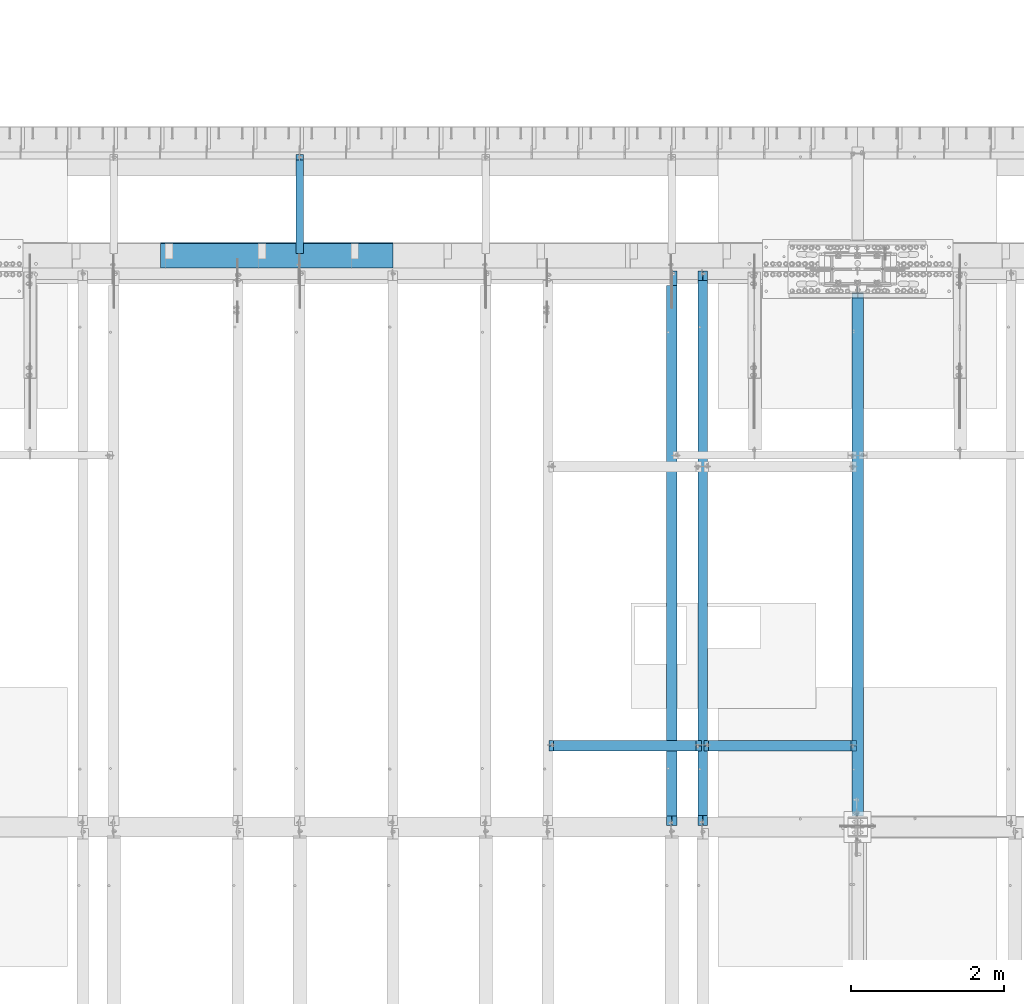
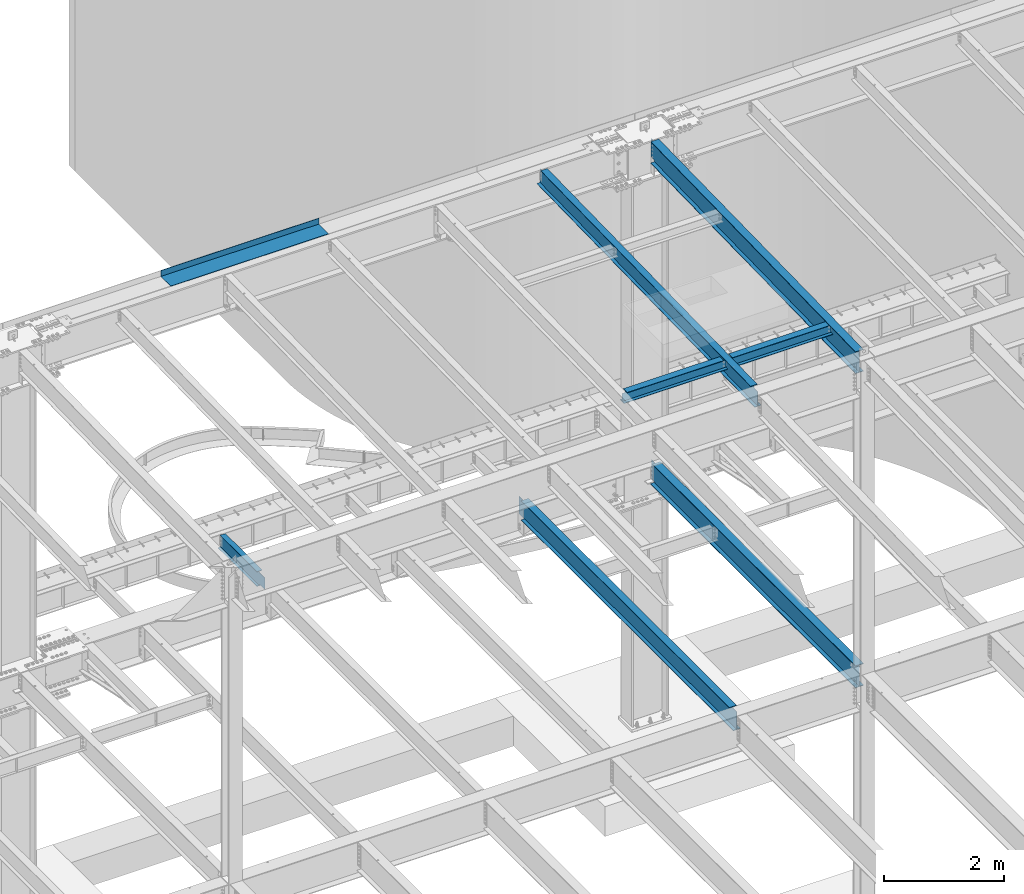
# One storey, part 1134 of 1763: 8 beams, 8 elements without a shape of their own.
"""IFC2X3 building model written with IfcOpenShell, lengths in millimetres."""

from ifc_helpers import new_model, si_unit, frame, origin_with_axes, place, context, subcontext, project, spatial, faceted_brep, material, type_object, element, aggregate, save


model = new_model("IFC2X3")

# Units and contexts
model_context = context("Model", 3, precision=1e-05, world=origin_with_axes())
body_context = subcontext(model_context, "Body", "Model", "MODEL_VIEW")
ifc_project = project(units=[si_unit("LENGTHUNIT", "METRE", prefix="MILLI"), si_unit("AREAUNIT", "SQUARE_METRE"), si_unit("VOLUMEUNIT", "CUBIC_METRE"), si_unit("MASSUNIT", "GRAM", prefix="KILO"), si_unit("TIMEUNIT", "SECOND"), si_unit("PLANEANGLEUNIT", "RADIAN"), si_unit("SOLIDANGLEUNIT", "STERADIAN"), si_unit("THERMODYNAMICTEMPERATUREUNIT", "DEGREE_CELSIUS"), si_unit("LUMINOUSINTENSITYUNIT", "LUMEN")], contexts=[model_context])

# Site, building, storey
site_placement = place(None, origin_with_axes())
site = spatial("IfcSite", under=ifc_project, at=site_placement, CompositionType="ELEMENT")
building_placement = place(site_placement, origin_with_axes())
building = spatial("IfcBuilding", under=site, at=building_placement, Name="Undefined", CompositionType="ELEMENT")
storey_placement = place(building_placement, origin_with_axes())
storey = spatial("IfcBuildingStorey", under=building, at=storey_placement, Name="Undefined", CompositionType="ELEMENT", Elevation=0.0)

# Assembly, beam
assembly_1_placement = place(storey_placement, origin_with_axes())
assembly_1 = element("IfcElementAssembly", 1, at=assembly_1_placement, inside=storey, Name="BEAM", AssemblyPlace="NOTDEFINED", PredefinedType="RIGID_FRAME")
ifc_material_1 = material(Name="STEEL/A992")
beam_type_1 = type_object("IfcBeamType", Name="W8X18", PredefinedType="NOTDEFINED")
beam_1_placement = place(assembly_1_placement, frame((-53466.5223188412, 45872.003125, 11515.9111170495), z_axis=(0.0, 0.0, 1.0), x_axis=(1.0, 0.0, 0.0)))
beam_1 = element("IfcBeam", 2, at=beam_1_placement, type_object=beam_type_1, material=ifc_material_1, Name="BEAM", ObjectType="W8X18", context=body_context, shape_type="Brep", body=[
    faceted_brep([(1947.72688668019, -3.17500000383734, 68.5472454981009), (1947.7268866802, 3.1749999961612, 68.5472454981009), (1946.86590192084, 3.17499999616848, 69.8358002505338), (1946.86590177228, -3.17500000383006, 69.8358004728379), (1951.84706314834, -3.17500000384462, 65.7942315976234), (1951.84706314836, 3.17499999615393, 65.7942315976234), (1956.70714266639, -3.17500000385189, 64.8275016750358), (1956.7071426664, 3.17499999614665, 64.8275016750358), (2015.44464294919, -3.17500000397558, 64.8275016750358), (2015.44464276504, 3.17499999602296, 64.8275016750358), (1946.13938981476, -3.17500000383006, 70.3212402430472), (1946.13938963061, 3.17499999616848, 70.3212402430472), (1943.38637573014, 3.17499999617576, 74.4414167112009), (1943.38637591428, -3.17500000383006, 74.4414167112009), (1942.41964580755, 3.17499999617576, 79.3014962292473), (1942.41964599169, -3.17500000382279, 79.3014962292473), (76.1999968561649, 3.17499999984284, 95.25), (76.1999950146637, 66.6749999998428, 95.25), (1942.41964396604, 66.6749999961758, 95.25), (1942.41964580755, 3.17499999617576, 95.25), (76.1999988818134, -66.6750000001557, 103.1875), (76.1999988818134, -66.6750000001557, 95.25), (1942.41964783319, -66.6750000038228, 95.25), (1942.41964783319, -66.6750000038228, 103.1875), (76.1999950146637, 66.6749999998428, 103.1875), (1942.41964396604, 66.6749999961758, 103.1875), (1942.41964599169, -3.17500000382279, 95.25), (76.1999970403122, -3.17500000015571, 95.25), (76.1999968561649, 3.17499999984284, 79.3014961863064), (76.1999970403122, -3.17500000015571, 79.3014961863064), (75.2332669335738, 3.17499999985012, 74.44141666826), (75.233267117721, -3.17500000014843, 74.44141666826), (72.4802530330999, 3.17499999985012, 70.3212402001063), (72.4802532172471, -3.17500000014843, 70.3212402001063), (71.7537410457226, 3.17499999985739, 69.83580040995), (71.7537408971693, -3.17500000014115, 69.8358001876459), (70.8927561769378, 3.17499999985739, 68.5472454937626), (70.8927561769233, -3.17500000014115, 68.5472454937626), (66.7725797087842, 3.17499999986467, 65.7942315932851), (66.7725797087696, -3.17500000013388, 65.7942315932851), (61.912500190745, 3.17499999987194, 64.8275016706975), (61.9125001907232, -3.1750000001266, 64.8275016706975), (15.8749999079228, 3.17499999996653, 64.8275016706975), (15.87500009207, -3.17500000003201, 64.8275016706975), (15.8749999079228, 3.17499999996653, -95.25), (15.8749980664215, 66.6749999999665, -95.25), (15.8749980664215, 66.6749999999665, -103.1875), (15.8750019335712, -66.675000000032, -103.1875), (15.8750019335712, -66.675000000032, -95.25), (15.87500009207, -3.17500000003201, -95.25), (2015.44464276504, 3.17499999602296, -95.25), (2015.44464092355, 66.674999996023, -95.25), (2015.44464092355, 66.674999996023, -103.1875), (2015.4446447907, -66.6750000039756, -103.1875), (2015.4446447907, -66.6750000039756, -95.25), (2015.44464294919, -3.17500000397558, -95.25)], [[[0, 1, 2, 3]], [[4, 5, 1, 0]], [[6, 7, 5, 4]], [[8, 9, 7, 6]], [[10, 11, 12, 13]], [[13, 12, 14, 15]], [[16, 17, 18, 19]], [[20, 21, 22, 23]], [[24, 20, 23, 25]], [[17, 24, 25, 18]], [[23, 22, 26, 15, 14, 19, 18, 25]], [[21, 27, 26, 22]], [[20, 24, 17, 16, 28, 29, 27, 21]], [[29, 28, 30, 31]], [[31, 30, 32, 33]], [[33, 32, 34, 35]], [[35, 34, 36, 37]], [[37, 36, 38, 39]], [[39, 38, 40, 41]], [[41, 40, 42, 43]], [[44, 45, 46, 47, 48, 49, 43, 42]], [[45, 44, 50, 51]], [[46, 45, 51, 52]], [[47, 46, 52, 53]], [[48, 47, 53, 54]], [[49, 48, 54, 55]], [[4, 0, 3, 10, 13, 15, 26, 27, 29, 31, 33, 35, 37, 39, 41, 43, 49, 55, 8, 6]], [[11, 10, 3, 2]], [[50, 44, 42, 40, 38, 36, 34, 32, 30, 28, 16, 19, 14, 12, 11, 2, 1, 5, 7, 9]], [[55, 54, 53, 52, 51, 50, 9, 8]]]),
])
aggregate(assembly_1, [beam_1])

assembly_2_placement = place(storey_placement, origin_with_axes())
assembly_2 = element("IfcElementAssembly", 3, at=assembly_2_placement, inside=storey, Name="BEAM", AssemblyPlace="NOTDEFINED", PredefinedType="RIGID_FRAME")
beam_2_placement = place(assembly_2_placement, frame((-51434.5223188412, 45872.003125, 11515.9111170495), z_axis=(0.0, 0.0, 1.0), x_axis=(1.0, 0.0, 0.0)))
beam_2 = element("IfcBeam", 4, at=beam_2_placement, type_object=beam_type_1, material=ifc_material_1, Name="BEAM", ObjectType="W8X18", context=body_context, shape_type="Brep", body=[
    faceted_brep([(1947.72688668019, -3.17500000383734, 68.5472454981009), (1947.7268866802, 3.1749999961612, 68.5472454981009), (1946.86590192084, 3.17499999616848, 69.8358002505338), (1946.86590177228, -3.17500000383006, 69.8358004728379), (1951.84706314834, -3.17500000384462, 65.7942315976234), (1951.84706314836, 3.17499999615393, 65.7942315976234), (1956.70714266639, -3.17500000385189, 64.8275016750358), (1956.7071426664, 3.17499999614665, 64.8275016750358), (2015.44464294919, -3.17500000397558, 64.8275016750358), (2015.44464276504, 3.17499999602296, 64.8275016750358), (1946.13938981476, -3.17500000383006, 70.3212402430472), (1946.13938963061, 3.17499999616848, 70.3212402430472), (1943.38637573014, 3.17499999617576, 74.4414167112009), (1943.38637591428, -3.17500000383006, 74.4414167112009), (1942.41964580755, 3.17499999617576, 79.3014962292473), (1942.41964599169, -3.17500000382279, 79.3014962292473), (76.1999968561649, 3.17499999984284, 95.25), (76.1999950146637, 66.6749999998428, 95.25), (1942.41964396604, 66.6749999961758, 95.25), (1942.41964580755, 3.17499999617576, 95.25), (76.1999988818134, -66.6750000001557, 103.1875), (76.1999988818134, -66.6750000001557, 95.25), (1942.41964783319, -66.6750000038228, 95.25), (1942.41964783319, -66.6750000038228, 103.1875), (76.1999950146637, 66.6749999998428, 103.1875), (1942.41964396604, 66.6749999961758, 103.1875), (1942.41964599169, -3.17500000382279, 95.25), (76.1999970403122, -3.17500000015571, 95.25), (76.1999968561649, 3.17499999984284, 79.3014961863064), (76.1999970403122, -3.17500000015571, 79.3014961863064), (75.2332669335738, 3.17499999985012, 74.44141666826), (75.233267117721, -3.17500000014843, 74.44141666826), (72.4802530330999, 3.17499999985012, 70.3212402001063), (72.4802532172471, -3.17500000014843, 70.3212402001063), (71.7537410457226, 3.17499999985739, 69.83580040995), (71.7537408971693, -3.17500000014115, 69.8358001876459), (70.8927561769378, 3.17499999985739, 68.5472454937626), (70.8927561769233, -3.17500000014115, 68.5472454937626), (66.7725797087842, 3.17499999986467, 65.7942315932851), (66.7725797087696, -3.17500000013388, 65.7942315932851), (61.912500190745, 3.17499999987194, 64.8275016706975), (61.9125001907232, -3.1750000001266, 64.8275016706975), (15.8749999079228, 3.17499999996653, 64.8275016706975), (15.87500009207, -3.17500000003201, 64.8275016706975), (15.8749999079228, 3.17499999996653, -95.25), (15.8749980664215, 66.6749999999665, -95.25), (15.8749980664215, 66.6749999999665, -103.1875), (15.8750019335712, -66.675000000032, -103.1875), (15.8750019335712, -66.675000000032, -95.25), (15.87500009207, -3.17500000003201, -95.25), (2015.44464276504, 3.17499999602296, -95.25), (2015.44464092355, 66.674999996023, -95.25), (2015.44464092355, 66.674999996023, -103.1875), (2015.4446447907, -66.6750000039756, -103.1875), (2015.4446447907, -66.6750000039756, -95.25), (2015.44464294919, -3.17500000397558, -95.25)], [[[0, 1, 2, 3]], [[4, 5, 1, 0]], [[6, 7, 5, 4]], [[8, 9, 7, 6]], [[10, 11, 12, 13]], [[13, 12, 14, 15]], [[16, 17, 18, 19]], [[20, 21, 22, 23]], [[24, 20, 23, 25]], [[17, 24, 25, 18]], [[23, 22, 26, 15, 14, 19, 18, 25]], [[21, 27, 26, 22]], [[20, 24, 17, 16, 28, 29, 27, 21]], [[29, 28, 30, 31]], [[31, 30, 32, 33]], [[33, 32, 34, 35]], [[35, 34, 36, 37]], [[37, 36, 38, 39]], [[39, 38, 40, 41]], [[41, 40, 42, 43]], [[44, 45, 46, 47, 48, 49, 43, 42]], [[45, 44, 50, 51]], [[46, 45, 51, 52]], [[47, 46, 52, 53]], [[48, 47, 53, 54]], [[49, 48, 54, 55]], [[4, 0, 3, 10, 13, 15, 26, 27, 29, 31, 33, 35, 37, 39, 41, 43, 49, 55, 8, 6]], [[11, 10, 3, 2]], [[50, 44, 42, 40, 38, 36, 34, 32, 30, 28, 16, 19, 14, 12, 11, 2, 1, 5, 7, 9]], [[55, 54, 53, 52, 51, 50, 9, 8]]]),
])
aggregate(assembly_2, [beam_2])

assembly_3_placement = place(storey_placement, origin_with_axes())
assembly_3 = element("IfcElementAssembly", 5, at=assembly_3_placement, inside=storey, Name="BEAM", AssemblyPlace="NOTDEFINED", PredefinedType="RIGID_FRAME")
beam_type_2 = type_object("IfcBeamType", Name="W16X26", PredefinedType="NOTDEFINED")
beam_3_placement = place(assembly_3_placement, frame((-51840.8372736984, 44805.6, 4994.275), z_axis=(0.0, 0.0, 1.0), x_axis=(0.0, 1.0, 0.0)))
beam_3 = element("IfcBeam", 6, at=beam_3_placement, type_object=beam_type_2, material=ifc_material_1, Name="BEAM", ObjectType="W16X26", context=body_context, shape_type="Brep", body=[
    faceted_brep([(7104.06248869727, 3.17500000000291, -190.5), (7104.06248869734, 3.17487653380522, -200.025), (7104.06247902929, 69.8499999999985, -200.025), (7104.06247902929, 69.8499999999985, -190.5), (7294.5625, 3.17500000000291, -190.5), (7294.5625, 3.17490415680368, -200.025), (146.04999924302, 3.17499999999927, 190.5), (146.04999924302, 69.8499999999985, 190.5), (7104.0625, 69.8499999999985, 190.5), (7104.0625, 3.17500000000291, 190.5), (146.04999943226, -69.8499999999985, 200.025), (146.04999943226, 69.8499999999985, 200.025), (146.04999943226, 3.17500000000291, 180.715001487731), (146.04999943226, -3.17500000000291, 180.715001487731), (146.04999924302, -3.17499999999927, 190.5), (146.04999924302, -69.8499999999985, 190.5), (145.083269509669, 3.17500000000291, 175.854921969685), (145.083269509669, -3.17500000000291, 175.854921969685), (142.330255609195, 3.17500000000291, 171.734745501532), (142.330255609195, -3.17500000000291, 171.734745501532), (138.210079141041, 3.17500000000291, 168.981731601053), (138.210079141041, -3.17500000000291, 168.981731601053), (133.349999622995, 3.17500000000291, 168.015001678466), (133.349999622995, -3.17500000000291, 168.015001678466), (19.0499999999956, 3.17500000000291, 168.015001678466), (19.0499999999956, -3.17500000000291, 168.015001678466), (19.0499999999956, 3.17499999999927, -190.5), (19.0499999999956, 69.8499999999985, -190.5), (19.0499999999956, 69.8499999999985, -200.025), (19.0499999999956, -69.8499999999985, -200.025), (19.0499999999956, -69.8499999999985, -190.5), (19.0499999999956, -3.17499999999927, -190.5), (7294.5625, -69.8499999999985, -200.025), (7294.5625, -69.8499999999985, -190.5), (7294.5625, -3.17500000000291, -190.5), (7111.90242029122, -3.17500000000291, 156.541729922587), (7107.78224382307, -3.17500000000291, 159.294743823066), (7105.02922992258, -3.17500000000291, 163.414920291219), (7104.0625, -3.17500000000291, 168.274999809265), (7104.0625, -3.17500000000291, 190.5), (7294.5625, -3.17500000000291, 155.575), (7116.76249980927, -3.17500000000291, 155.575), (7104.0625, -69.8499999999985, 190.5), (7104.0625, -69.8499999999985, 200.025), (7104.0625, 69.8499999999985, 200.025), (7104.0625, 3.17500000000291, 168.274999809265), (7105.02922992258, 3.17500000000291, 163.414920291219), (7107.78224382307, 3.17500000000291, 159.294743823066), (7111.90242029122, 3.17500000000291, 156.541729922587), (7116.76249980927, 3.17500000000291, 155.575), (7294.5625, 3.17500000000291, 155.575), (7294.5625, 3.17500000000291, -184.976846570121)], [[[0, 1, 2, 3]], [[4, 5, 1, 0]], [[6, 7, 8, 9]], [[10, 11, 7, 6, 12, 13, 14, 15]], [[13, 12, 16, 17]], [[17, 16, 18, 19]], [[19, 18, 20, 21]], [[21, 20, 22, 23]], [[23, 22, 24, 25]], [[26, 27, 28, 29, 30, 31, 25, 24]], [[30, 29, 32, 33]], [[31, 30, 33, 34]], [[35, 36, 37, 38, 39, 14, 13, 17, 19, 21, 23, 25, 31, 34, 40, 41]], [[15, 14, 39, 42]], [[10, 15, 42, 43]], [[11, 10, 43, 44]], [[7, 11, 44, 8]], [[43, 42, 39, 38, 45, 9, 8, 44]], [[37, 46, 45, 38]], [[36, 47, 46, 37]], [[35, 48, 47, 36]], [[41, 49, 48, 35]], [[40, 50, 49, 41]], [[51, 4, 0, 26, 24, 22, 20, 18, 16, 12, 6, 9, 45, 46, 47, 48, 49, 50]], [[27, 26, 0, 3]], [[28, 27, 3, 2]], [[32, 29, 28, 2, 1, 5]], [[51, 50, 40, 34, 33, 32, 5, 4]]]),
])
aggregate(assembly_3, [beam_3])

assembly_4_placement = place(storey_placement, origin_with_axes())
assembly_4 = element("IfcElementAssembly", 7, at=assembly_4_placement, inside=storey, Name="BEAM", AssemblyPlace="NOTDEFINED", PredefinedType="RIGID_FRAME")
beam_type_3 = type_object("IfcBeamType", Name="W14X22", PredefinedType="NOTDEFINED")
beam_4_placement = place(assembly_4_placement, frame((-51434.4372736983, 44809.2121579121, 11421.5633921212), z_axis=(0.0, -0.0206852279954837, 0.999786037781472), x_axis=(0.0, 0.999786037781472, 0.0206852279954825)))
beam_4 = element("IfcBeam", 8, at=beam_4_placement, type_object=beam_type_3, material=ifc_material_1, Name="BEAM", ObjectType="W14X22", context=body_context, shape_type="Brep", body=[
    faceted_brep([(136.091146049795, -3.17500000000291, 123.565001678358), (136.091146049795, 3.17500000000291, 123.565001678358), (17.9976630864912, 3.17500000000291, 123.56500167838), (17.9976630864912, -3.17500000000291, 123.56500167838), (140.951225567893, -3.17500000000291, 124.531731600942), (140.951225567893, 3.17500000000291, 124.531731600942), (145.071402036083, -3.17500000000291, 127.284745501414), (145.071402036083, 3.17500000000291, 127.284745501414), (147.824415936586, -3.17500000000291, 131.404921969557), (147.824415936586, 3.17500000000291, 131.404921969557), (148.791145859177, -3.17500000000291, 136.265001487593), (148.791145859177, 3.17500000000291, 136.265001487593), (148.79114585917, -63.5, 174.624999999827), (148.79114585917, 63.5, 174.624999999827), (148.791145859177, 63.5, 166.687499999833), (148.791145859177, 3.17500000000291, 166.687499999833), (148.791145859177, -3.17500000000291, 166.687499999833), (148.791145859177, -63.5, 166.687499999833), (11.9924390219312, -3.17500000000291, -166.687499999878), (11.9924390219312, -63.5, -166.687499999878), (7289.06195724197, -63.5, -166.687500001812), (7289.06195724197, -3.17500000000291, -166.687500001812), (11.8282148869548, -63.5, -174.624999999871), (7288.89773310699, -63.5, -174.625000001806), (11.8282148869548, 63.5, -174.624999999871), (7288.89773310699, 63.5, -174.625000001806), (11.9924390219312, 63.5, -166.687499999878), (7289.06195724197, 63.5, -166.687500001812), (11.9924390219312, 3.17500000000291, -166.687499999878), (7289.06195724197, 3.17500000000291, -166.687500001812), (7294.93580191941, 3.17500000000291, 117.21499785159), (7294.93580191941, -3.17500000000291, 117.21499785159), (7178.21066392501, 3.17500000000291, 117.214997851612), (7178.21066392501, -3.17500000000291, 117.214997851612), (7173.35058440694, 3.17500000000291, 118.181727774199), (7173.35058440694, -3.17500000000291, 118.181727774199), (7169.23040793875, 3.17500000000291, 120.934741674671), (7169.23040793875, -3.17500000000291, 120.934741674671), (7166.47739403824, 3.17500000000291, 125.054918142816), (7166.47739403824, -3.17500000000291, 125.054918142816), (7165.51066411565, 3.17500000000291, 129.91499766085), (7165.51066411565, -3.17500000000291, 129.91499766085), (7165.51066411565, -63.5, 174.624999997965), (7165.51066411565, -63.5, 166.68749999797), (7165.51066411565, -3.17500000000291, 166.68749999797), (7165.51066411565, 3.17500000000291, 166.68749999797), (7165.51066411565, 63.5, 166.68749999797), (7165.51066411565, 63.5, 174.624999997965)], [[[0, 1, 2, 3]], [[4, 5, 1, 0]], [[6, 7, 5, 4]], [[8, 9, 7, 6]], [[10, 11, 9, 8]], [[12, 13, 14, 15, 11, 10, 16, 17]], [[18, 19, 20, 21]], [[19, 22, 23, 20]], [[22, 24, 25, 23]], [[24, 26, 27, 25]], [[26, 28, 29, 27]], [[21, 20, 23, 25, 27, 29, 30, 31]], [[31, 30, 32, 33]], [[33, 32, 34, 35]], [[35, 34, 36, 37]], [[37, 36, 38, 39]], [[39, 38, 40, 41]], [[42, 43, 44, 41, 40, 45, 46, 47]], [[43, 42, 12, 17]], [[44, 43, 17, 16]], [[8, 6, 4, 0, 3, 18, 21, 31, 33, 35, 37, 39, 41, 44, 16, 10]], [[28, 26, 24, 22, 19, 18, 3, 2]], [[45, 40, 38, 36, 34, 32, 30, 29, 28, 2, 1, 5, 7, 9, 11, 15]], [[46, 45, 15, 14]], [[47, 46, 14, 13]], [[42, 47, 13, 12]]]),
])
aggregate(assembly_4, [beam_4])

assembly_5_placement = place(storey_placement, origin_with_axes())
assembly_5 = element("IfcElementAssembly", 9, at=assembly_5_placement, inside=storey, Name="BEAM", AssemblyPlace="NOTDEFINED", PredefinedType="RIGID_FRAME")
ifc_material_2 = material(Name="STEEL/A36")
beam_type_4 = type_object("IfcBeamType", PredefinedType="NOTDEFINED")
beam_5_placement = place(assembly_5_placement, frame((-57019.2617736983, 52133.5000002128, 11752.2624917654), z_axis=(-1.0, 0.0, 0.0), x_axis=(0.0, 1.0, 0.0)))
beam_5 = element("IfcBeam", 10, at=beam_5_placement, type_object=beam_type_4, material=ifc_material_2, Name="BENT_PLATE", context=body_context, shape_type="Brep", body=[
    faceted_brep([(0.0, -4.76249999999982, -1524.0), (0.0, -4.76249999999982, 1524.0), (0.0, 4.76249999999982, 1524.0), (0.0, 4.76249999999982, -1524.0), (336.549987792969, 4.76250000000073, 1524.0), (336.549987792969, 4.76250000000073, -1524.0), (327.024987792975, -4.76250000000073, -1524.0), (327.024987792967, -4.76250000000073, 1524.00000000001), (336.549987792969, -122.237499999999, 1524.0), (336.549987792969, -122.237499999999, -1524.0), (327.024987792975, -122.237499999999, 1524.0), (327.024987792975, -122.237499999999, -1524.0)], [[[0, 1, 2, 3]], [[3, 2, 4, 5]], [[1, 0, 6, 7]], [[5, 4, 8, 9]], [[4, 2, 1, 7, 10, 8]], [[7, 6, 11, 10]], [[6, 0, 3, 5, 9, 11]], [[10, 11, 9, 8]]]),
])
aggregate(assembly_5, [beam_5])

assembly_6_placement = place(storey_placement, origin_with_axes())
assembly_6 = element("IfcElementAssembly", 11, at=assembly_6_placement, inside=storey, Name="BEAM", AssemblyPlace="NOTDEFINED", PredefinedType="RIGID_FRAME")
beam_type_5 = type_object("IfcBeamType", Name="W12X16", PredefinedType="NOTDEFINED")
beam_6_placement = place(assembly_6_placement, frame((-56717.6372736983, 52120.8, 5041.9), z_axis=(0.0, 0.0, 1.0), x_axis=(0.0, 1.0, 0.0)))
beam_6 = element("IfcBeam", 12, at=beam_6_placement, type_object=beam_type_5, material=ifc_material_1, Name="BEAM", ObjectType="W12X16", context=body_context, shape_type="Brep", body=[
    faceted_brep([(20.6374999999971, -3.17500000000291, -114.3), (20.6374999999971, 3.17500000000291, -114.3), (192.087500190733, 3.17500000000291, -114.3), (192.087500190733, -3.17500000000291, -114.3), (196.94757970878, 3.17500000000291, -115.266729922588), (196.94757970878, -3.17500000000291, -115.266729922588), (201.067756176933, 3.17500000000291, -118.019743823066), (201.067756176933, -3.17500000000291, -118.019743823066), (203.820770077407, 3.17500000000291, -122.13992029122), (203.820770077407, -3.17500000000291, -122.13992029122), (204.787499999999, -3.17500000000291, -126.999999809265), (204.787499999999, 3.17500000000291, -126.999999809265), (204.787499999999, 3.17500000000291, -146.05), (204.787499999999, 50.8000000000029, -146.05), (204.787499999999, 50.8000000000029, -152.4), (204.787499999999, -50.8000000000029, -152.4), (204.787499999999, -50.8000000000029, -146.05), (204.787499999999, -3.17500000000291, -146.05), (1431.13125000001, 50.8000000000029, 146.05), (1431.13125000001, 3.17500000000291, 146.05), (204.787499999999, 3.17500000000291, 146.05), (204.787499999999, 50.8000000000029, 146.05), (192.087500190733, -3.17500000000291, 114.3), (192.087500190733, 3.17500000000291, 114.3), (20.6374999999971, 3.17500000000291, 114.3), (20.6374999999971, -3.17500000000291, 114.3), (196.94757970878, -3.17500000000291, 115.266729922588), (196.94757970878, 3.17500000000291, 115.266729922588), (201.067756176933, -3.17500000000291, 118.019743823066), (201.067756176933, 3.17500000000291, 118.019743823066), (203.820770077407, -3.17500000000291, 122.13992029122), (203.820770077407, 3.17500000000291, 122.13992029122), (204.787499999999, -3.17500000000291, 126.999999809265), (204.787499999999, 3.17500000000291, 126.999999809265), (1431.13125000001, -50.8000000000029, 152.4), (1431.13125000001, 50.8000000000029, 152.4), (204.787499999999, 50.8000000000029, 152.4), (204.787499999999, -50.8000000000029, 152.4), (1431.13125000001, -50.8000000000029, 146.05), (204.787499999999, -50.8000000000029, 146.05), (1431.13125000001, -3.17500000000291, 146.05), (204.787499999999, -3.17500000000291, 146.05), (1431.13125000001, -3.17500000000291, 139.440001487732), (1431.13125000001, 3.17500000000291, 139.440001487732), (1432.0979799226, -3.17500000000291, 134.579921969686), (1432.0979799226, 3.17500000000291, 134.579921969686), (1434.85099382307, -3.17500000000291, 130.459745501533), (1434.85099382307, 3.17500000000291, 130.459745501533), (1438.97117029122, -3.17500000000291, 127.706731601054), (1438.97117029122, 3.17500000000291, 127.706731601054), (1443.83124980927, -3.17500000000291, 126.740001678467), (1443.83124980927, 3.17500000000291, 126.740001678467), (1507.33125, -3.17500000000291, 126.740001678467), (1507.33125, 3.17500000000291, 126.740001678467), (1507.33125, -3.17500000000291, -146.05), (1507.33125, -50.8000000000029, -146.05), (1507.33125, -50.8000000000029, -152.4), (1507.33125, 50.8000000000029, -152.4), (1507.33125, 50.8000000000029, -146.05), (1507.33125, 3.17500000000291, -146.05)], [[[0, 1, 2, 3]], [[3, 2, 4, 5]], [[5, 4, 6, 7]], [[7, 6, 8, 9]], [[10, 11, 12, 13, 14, 15, 16, 17]], [[9, 8, 11, 10]], [[18, 19, 20, 21]], [[22, 23, 24, 25]], [[26, 27, 23, 22]], [[28, 29, 27, 26]], [[30, 31, 29, 28]], [[32, 33, 31, 30]], [[34, 35, 36, 37]], [[38, 34, 37, 39]], [[40, 38, 39, 41]], [[37, 36, 21, 20, 33, 32, 41, 39]], [[35, 18, 21, 36]], [[34, 38, 40, 42, 43, 19, 18, 35]], [[44, 45, 43, 42]], [[46, 47, 45, 44]], [[48, 49, 47, 46]], [[50, 51, 49, 48]], [[52, 53, 51, 50]], [[54, 55, 56, 57, 58, 59, 53, 52]], [[55, 54, 17, 16]], [[56, 55, 16, 15]], [[57, 56, 15, 14]], [[58, 57, 14, 13]], [[59, 58, 13, 12]], [[6, 4, 2, 1, 24, 23, 27, 29, 31, 33, 20, 19, 43, 45, 47, 49, 51, 53, 59, 12, 11, 8]], [[25, 24, 1, 0]], [[54, 52, 50, 48, 46, 44, 42, 40, 41, 32, 30, 28, 26, 22, 25, 0, 3, 5, 7, 9, 10, 17]]]),
])
aggregate(assembly_6, [beam_6])

assembly_7_placement = place(storey_placement, origin_with_axes())
assembly_7 = element("IfcElementAssembly", 13, at=assembly_7_placement, inside=storey, Name="BEAM", AssemblyPlace="NOTDEFINED", PredefinedType="RIGID_FRAME")
beam_type_6 = type_object("IfcBeamType", Name="W18X35", PredefinedType="NOTDEFINED")
beam_7_placement = place(assembly_7_placement, frame((-49402.4372736983, 44810.2629674943, 11370.7742614019), z_axis=(0.0, -0.0206852279954837, 0.999786037781472), x_axis=(0.0, 0.999786037781472, 0.0206852279954825)))
beam_7 = element("IfcBeam", 14, at=beam_7_placement, type_object=beam_type_6, material=ifc_material_1, Name="BEAM", ObjectType="W18X35", context=body_context, shape_type="Brep", body=[
    faceted_brep([(6981.85534172427, -3.96875, -214.312500001693), (6981.85534172427, -76.1999999999971, -214.312500001693), (6981.85534172427, -76.1999999999971, -225.425000001685), (6981.85534172427, 76.1999999999971, -225.425000001685), (6981.85534172427, 76.1999999999971, -214.312500001693), (6981.85534172427, 3.96875, -214.312500001693), (6981.85534172429, 3.96875, -200.284999820729), (6981.85534172429, -3.96875, -200.284999820729), (6982.82207164688, 3.96875, -195.424920302696), (6982.82207164688, -3.96875, -195.424920302696), (6985.57508554738, 3.96875, -191.304743834553), (6985.57508554738, -3.96875, -191.304743834553), (6989.69526201557, 3.96875, -188.551729934081), (6989.69526201557, -3.96875, -188.551729934081), (6994.55534153366, 3.96875, -187.585000011497), (6994.55534153366, -3.96875, -187.585000011497), (7092.27427279067, -3.96875, -187.585000011552), (7092.27427279067, 3.96875, -187.585000011552), (144.263502213013, 3.96875, 214.312499999811), (144.263502213013, 76.1999999999971, 214.312499999811), (6981.85534172432, 76.1999999999971, 214.312499997985), (6981.85534172432, 3.96875, 214.312499997985), (135.16548513544, -76.1999999999971, -225.424999999856), (135.395398924404, -76.1999999999971, -214.312499999864), (135.395398924404, -3.96875, -214.312499999864), (144.263502213013, -3.96875, 214.312499999811), (144.263502213013, -76.1999999999971, 214.312499999811), (144.493416001977, -76.1999999999971, 225.424999999803), (144.493416001977, 76.1999999999971, 225.424999999803), (135.395398924404, 3.96875, -214.312499999864), (135.395398924404, 76.1999999999971, -214.312499999864), (135.16548513544, 76.1999999999971, -225.424999999856), (6981.85534172432, -3.96875, 214.312499997985), (6981.85534172432, -76.1999999999971, 214.312499997985), (6981.85534172433, -76.1999999999971, 225.424999997977), (6981.85534172433, 76.1999999999971, 225.424999997977), (6981.85534172432, -3.96875, 199.765001475287), (6981.85534172432, 3.96875, 199.765001475287), (6982.82207164692, -3.96875, 194.904921957252), (6982.82207164692, 3.96875, 194.904921957252), (6985.57508554743, -3.96875, 190.784745489109), (6985.57508554743, 3.96875, 190.784745489109), (6989.69526201561, -3.96875, 188.031731588633), (6989.69526201561, 3.96875, 188.031731588633), (6994.55534153371, -3.96875, 187.065001666047), (6994.55534153371, 3.96875, 187.065001666047), (7100.02565199621, -3.96875, 187.065001666027), (7100.02565199621, 3.96875, 187.065001666027)], [[[0, 1, 2, 3, 4, 5, 6, 7]], [[7, 6, 8, 9]], [[9, 8, 10, 11]], [[11, 10, 12, 13]], [[13, 12, 14, 15]], [[16, 15, 14, 17]], [[18, 19, 20, 21]], [[22, 23, 24, 25, 26, 27, 28, 19, 18, 29, 30, 31]], [[26, 25, 32, 33]], [[27, 26, 33, 34]], [[28, 27, 34, 35]], [[19, 28, 35, 20]], [[34, 33, 32, 36, 37, 21, 20, 35]], [[38, 39, 37, 36]], [[40, 41, 39, 38]], [[42, 43, 41, 40]], [[44, 45, 43, 42]], [[46, 47, 45, 44]], [[47, 46, 16, 17]], [[12, 10, 8, 6, 5, 29, 18, 21, 37, 39, 41, 43, 45, 47, 17, 14]], [[30, 29, 5, 4]], [[31, 30, 4, 3]], [[22, 31, 3, 2]], [[23, 22, 2, 1]], [[24, 23, 1, 0]], [[46, 44, 42, 40, 38, 36, 32, 25, 24, 0, 7, 9, 11, 13, 15, 16]]]),
])
aggregate(assembly_7, [beam_7])

assembly_8_placement = place(storey_placement, origin_with_axes())
assembly_8 = element("IfcElementAssembly", 15, at=assembly_8_placement, inside=storey, Name="BEAM", AssemblyPlace="NOTDEFINED", PredefinedType="RIGID_FRAME")
beam_type_7 = type_object("IfcBeamType", Name="W18X40", PredefinedType="NOTDEFINED")
beam_8_placement = place(assembly_8_placement, frame((-49402.4372736983, 44805.6, 4967.2875), z_axis=(0.0, 0.0, 1.0), x_axis=(0.0, 1.0, 0.0)))
beam_8 = element("IfcBeam", 16, at=beam_8_placement, type_object=beam_type_7, material=ifc_material_1, Name="BEAM", ObjectType="W18X40", context=body_context, shape_type="Brep", body=[
    faceted_brep([(6937.37498732733, -76.1999999999971, 214.3125), (6937.37498732733, -3.96875, 214.3125), (6937.60420254865, -3.96875, 213.91549911499), (6937.60420254865, 3.96875, 213.91549911499), (6937.37498732733, 3.96875, 214.3125), (6937.37498732733, 76.1999999999971, 214.3125), (6930.04242606437, 76.1999999999971, 227.0125), (6930.04242606437, -76.1999999999971, 227.0125), (144.462499999994, 76.1999999999971, -214.3125), (144.462499999994, 71.199821507762, -214.3125), (144.462499999994, 3.96875, -214.3125), (6999.89240878766, 3.96875, -214.3125), (6999.89240878766, 76.1999999999971, -214.3125), (6890.76589898111, -3.96875, 204.211830867132), (6890.76589898111, 3.96875, 204.211830867132), (6911.97500305174, 3.96875, 213.91549911499), (6911.97500305174, -3.96875, 213.91549911499), (6887.72798328583, -3.96875, 201.276913128712), (6887.72798328583, 3.96875, 201.276913128712), (6887.20337863325, -3.96875, 197.085557278698), (6887.20337863325, 3.96875, 197.085557278698), (6889.42422216828, -3.96875, 193.492434974088), (6889.42422216828, 3.96875, 193.492434974088), (6893.40779237872, -3.96875, 192.0875), (6893.40779237872, 3.96875, 192.0875), (7089.77499999998, -3.96875, 192.0875), (7089.77499999998, 3.96875, 192.0875), (7089.77499999998, -3.96875, -192.0875), (7089.77499999998, 3.96875, -192.0875), (6980.86678896075, -3.96875, -192.0875), (6980.86678896075, 3.96875, -192.0875), (6976.88321875031, -3.96875, -193.492434974089), (6976.88321875031, 3.96875, -193.492434974089), (6974.66237521528, -3.96875, -197.085557278698), (6974.66237521528, 3.96875, -197.085557278698), (6975.18697986786, -3.96875, -201.276913128712), (6975.18697986786, 3.96875, -201.276913128712), (6978.22489556314, -3.96875, -204.211830867132), (6978.22489556314, 3.96875, -204.211830867132), (6999.43399963377, -3.96875, -213.91549911499), (6999.43399963377, 3.96875, -213.91549911499), (144.462499999994, -76.1999999999971, -227.0125), (144.462499999994, -14.2685700086731, -227.0125), (144.462499999994, -5.73107306084421, -227.0125), (144.462499999994, 71.2001784793538, -227.0125), (144.462499999994, 76.1999999999971, -227.0125), (7007.22459707105, 76.1999999999971, -227.0125), (7007.22459707105, -76.1999999999971, -227.0125), (144.462499999994, -76.1999999999971, -214.3125), (6999.89240878766, -76.1999999999971, -214.3125), (144.462499999994, -3.96875, -214.3125), (144.462499999994, -5.73143003243604, -214.3125), (144.462499999994, -14.268926980265, -214.3125), (6999.89240878766, -3.96875, -214.3125), (144.462499999994, -3.96875, -205.614753375452), (144.462499999994, -3.96875, 214.3125), (144.462499999994, -76.1999999999971, 214.3125), (144.462499999994, -76.1999999999971, 227.0125), (144.462499999994, 76.1999999999971, 227.0125), (144.462499999994, 76.1999999999971, 214.3125), (144.462499999994, 3.96875, 214.3125), (144.462499999994, 3.96875, -205.614530268201)], [[[0, 1, 2, 3, 4, 5, 6, 7]], [[8, 9, 10, 11, 12]], [[13, 14, 15, 16]], [[17, 18, 14, 13]], [[19, 20, 18, 17]], [[21, 22, 20, 19]], [[23, 24, 22, 21]], [[24, 23, 25, 26]], [[25, 27, 28, 26]], [[29, 30, 28, 27]], [[31, 32, 30, 29]], [[33, 34, 32, 31]], [[35, 36, 34, 33]], [[37, 38, 36, 35]], [[38, 37, 39, 40]], [[41, 42, 43, 44, 45, 46, 47]], [[48, 41, 47, 49]], [[50, 51, 52, 48, 49, 53]], [[47, 46, 12, 11, 40, 39, 53, 49]], [[45, 8, 12, 46]], [[44, 43, 42, 41, 48, 52, 51, 50, 54, 55, 56, 57, 58, 59, 60, 61, 10, 9, 8, 45]], [[57, 56, 0, 7]], [[58, 57, 7, 6]], [[59, 58, 6, 5]], [[60, 59, 5, 4]], [[15, 14, 18, 20, 22, 24, 26, 28, 30, 32, 34, 36, 38, 40, 11, 10, 61, 60, 4, 3]], [[16, 15, 3, 2]], [[55, 54, 50, 53, 39, 37, 35, 33, 31, 29, 27, 25, 23, 21, 19, 17, 13, 16, 2, 1]], [[56, 55, 1, 0]]]),
])
aggregate(assembly_8, [beam_8])

save(model, "model.ifc")
